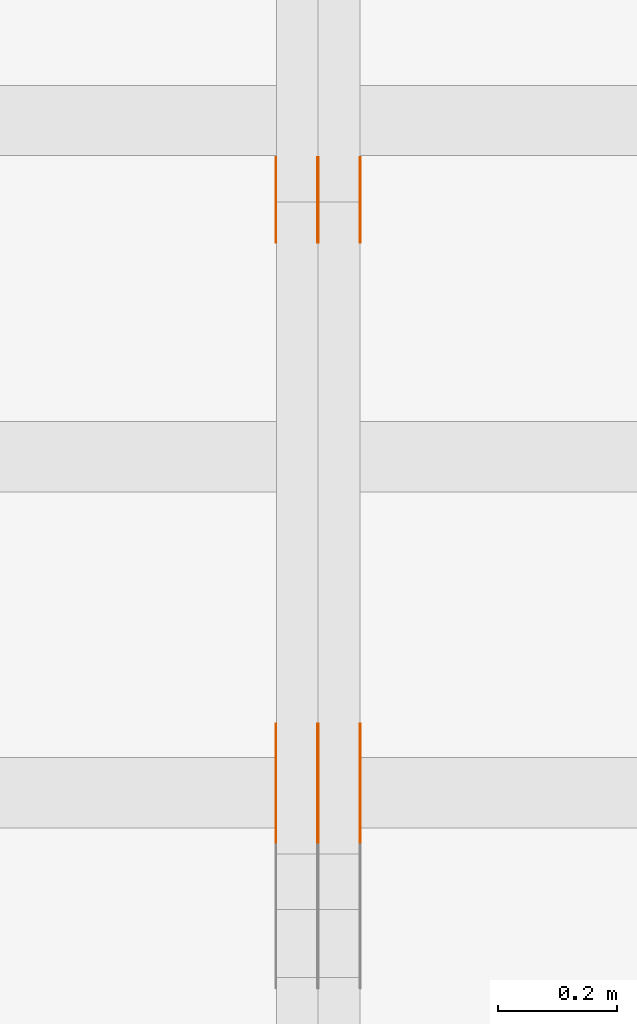
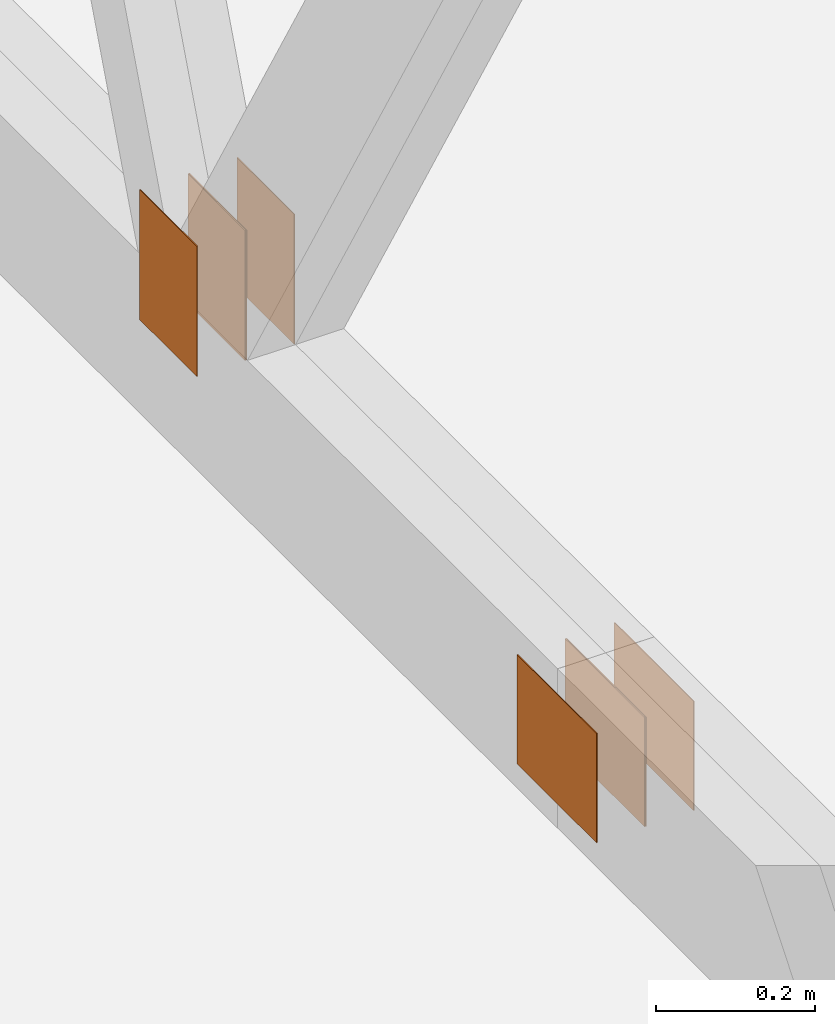
# One storey, part 94 of 189: 8 proxies.
"""IFC2X3 building model written with IfcOpenShell, lengths in millimetres."""

from ifc_helpers import new_model, entity, si_unit, converted_unit, derived_unit, direction, frame, frame_2d, origin, origin_2d_with_axis, place, context, subcontext, project, spatial, rectangle, extrude, source, transform, mapped, material, type_object, type_shapes, element, save


model = new_model("IFC2X3")

# Units and contexts
model_context = context("Model", 3, precision=0.01, world=origin(), true_north=direction((6.12303176911189e-17, 1.0)))
body_context = subcontext(model_context, "Body", "Model", "MODEL_VIEW")
ifc_project = project(units=[si_unit("LENGTHUNIT", "METRE", prefix="MILLI"), si_unit("AREAUNIT", "SQUARE_METRE"), si_unit("VOLUMEUNIT", "CUBIC_METRE"), converted_unit("PLANEANGLEUNIT", "DEGREE", entity("IfcRatioMeasure", 0.0174532925199433), si_unit("PLANEANGLEUNIT", "RADIAN"), dimensions=[0, 0, 0, 0, 0, 0, 0]), si_unit("MASSUNIT", "GRAM", prefix="KILO"), derived_unit("MASSDENSITYUNIT", [(si_unit("MASSUNIT", "GRAM", prefix="KILO"), 1), (si_unit("LENGTHUNIT", "METRE"), -3)]), si_unit("TIMEUNIT", "SECOND"), si_unit("FREQUENCYUNIT", "HERTZ"), si_unit("THERMODYNAMICTEMPERATUREUNIT", "DEGREE_CELSIUS"), derived_unit("THERMALTRANSMITTANCEUNIT", [(si_unit("MASSUNIT", "GRAM", prefix="KILO"), 1), (si_unit("THERMODYNAMICTEMPERATUREUNIT", "KELVIN"), -1), (si_unit("TIMEUNIT", "SECOND"), -3)]), derived_unit("VOLUMETRICFLOWRATEUNIT", [(si_unit("LENGTHUNIT", "METRE"), 3), (si_unit("TIMEUNIT", "SECOND"), -1)]), si_unit("ELECTRICCURRENTUNIT", "AMPERE"), si_unit("ELECTRICVOLTAGEUNIT", "VOLT"), si_unit("POWERUNIT", "WATT"), si_unit("FORCEUNIT", "NEWTON"), si_unit("ILLUMINANCEUNIT", "LUX"), si_unit("LUMINOUSFLUXUNIT", "LUMEN"), si_unit("LUMINOUSINTENSITYUNIT", "CANDELA"), derived_unit("USERDEFINED", [(si_unit("MASSUNIT", "GRAM", prefix="KILO"), -1), (si_unit("LENGTHUNIT", "METRE"), -2), (si_unit("TIMEUNIT", "SECOND"), 3), (si_unit("LUMINOUSFLUXUNIT", "LUMEN"), 1)]), derived_unit("LINEARVELOCITYUNIT", [(si_unit("LENGTHUNIT", "METRE"), 1), (si_unit("TIMEUNIT", "SECOND"), -1)]), si_unit("PRESSUREUNIT", "PASCAL"), derived_unit("USERDEFINED", [(si_unit("LENGTHUNIT", "METRE"), -2), (si_unit("MASSUNIT", "GRAM", prefix="KILO"), 1), (si_unit("TIMEUNIT", "SECOND"), -2)])], contexts=[model_context])

# Site, building, storey
site_placement = place(None, origin())
site = spatial("IfcSite", under=ifc_project, at=site_placement, CompositionType="ELEMENT")
building_placement = place(site_placement, origin())
building = spatial("IfcBuilding", under=site, at=building_placement, CompositionType="ELEMENT")
storey_placement = place(building_placement, origin())
storey = spatial("IfcBuildingStorey", under=building, at=storey_placement, Name="Default", CompositionType="ELEMENT", Elevation=0.0)

# Proxies
ifc_material_1 = material(Name="IfcSurfaceStyle #173742")
building_element_proxy_type_1 = type_object("IfcBuildingElementProxyType", PredefinedType="NOTDEFINED", material=ifc_material_1)
shared_shape_1 = source(origin(), body_context, "Body", "SweptSolid", [
    extrude(rectangle(XDim=200.0, YDim=144.0, at=frame_2d((1.4210854715202e-14, 0.0), x_axis=(1.0, 0.0))), frame((100.0, 72.0, 0.0), z_axis=(0.0, 0.0, 1.0), x_axis=(-1.0, 0.0, 0.0)), (0.0, 0.0, 1.0), 1.3),
])
type_shapes(building_element_proxy_type_1, [shared_shape_1])
proxy_1_placement = place(building_placement, frame((30301.3, 6668.833984375, 145.0), z_axis=(-1.0, 0.0, 0.0), x_axis=(0.0, 0.0, 1.0)))
element("IfcBuildingElementProxy", 1, at=proxy_1_placement, inside=storey, type_object=building_element_proxy_type_1, material=ifc_material_1, context=body_context, shape_type="MappedRepresentation", body=[
    mapped(shared_shape_1, transform((0.0, 0.0, 0.0), scale=1.0)),
])
ifc_material_2 = material(Name="IfcSurfaceStyle #173685")
building_element_proxy_type_2 = type_object("IfcBuildingElementProxyType", PredefinedType="NOTDEFINED", material=ifc_material_2)
shared_shape_2 = source(origin(), body_context, "Body", "SweptSolid", [
    extrude(rectangle(XDim=200.0, YDim=144.0, at=frame_2d((1.4210854715202e-14, 0.0), x_axis=(1.0, 0.0))), frame((100.0, 72.0, 0.0), z_axis=(0.0, 0.0, 1.0), x_axis=(-1.0, 0.0, 0.0)), (0.0, 0.0, 1.0), 1.29999999999998),
])
type_shapes(building_element_proxy_type_2, [shared_shape_2])
proxy_2_placement = place(building_placement, frame((30230.0, 6668.833984375, 145.0), z_axis=(-1.0, 0.0, 0.0), x_axis=(0.0, 0.0, 1.0)))
element("IfcBuildingElementProxy", 2, at=proxy_2_placement, inside=storey, type_object=building_element_proxy_type_2, material=ifc_material_2, context=body_context, shape_type="MappedRepresentation", body=[
    mapped(shared_shape_2, transform((0.0, 0.0, 0.0), scale=1.0)),
])
ifc_material_3 = material(Name="IfcSurfaceStyle #173628")
building_element_proxy_type_3 = type_object("IfcBuildingElementProxyType", PredefinedType="NOTDEFINED", material=ifc_material_3)
shared_shape_3 = source(origin(), body_context, "Body", "SweptSolid", [
    extrude(rectangle(XDim=200.0, YDim=144.0, at=frame_2d((1.4210854715202e-14, 0.0), x_axis=(1.0, 0.0))), frame((100.0, 72.0, 0.0), z_axis=(0.0, 0.0, 1.0), x_axis=(-1.0, 0.0, 0.0)), (0.0, 0.0, 1.0), 1.29999999999998),
])
type_shapes(building_element_proxy_type_3, [shared_shape_3])
proxy_3_placement = place(building_placement, frame((30231.3, 6668.833984375, 145.0), z_axis=(-1.0, 0.0, 0.0), x_axis=(0.0, 0.0, 1.0)))
element("IfcBuildingElementProxy", 3, at=proxy_3_placement, inside=storey, type_object=building_element_proxy_type_3, material=ifc_material_3, context=body_context, shape_type="MappedRepresentation", body=[
    mapped(shared_shape_3, transform((0.0, 0.0, 0.0), scale=1.0)),
])
ifc_material_4 = material(Name="IfcSurfaceStyle #173571")
building_element_proxy_type_4 = type_object("IfcBuildingElementProxyType", PredefinedType="NOTDEFINED", material=ifc_material_4)
shared_shape_4 = source(origin(), body_context, "Body", "SweptSolid", [
    extrude(rectangle(XDim=200.0, YDim=144.0, at=frame_2d((1.4210854715202e-14, 0.0), x_axis=(1.0, 0.0))), frame((100.0, 72.0, 0.0), z_axis=(0.0, 0.0, 1.0), x_axis=(-1.0, 0.0, 0.0)), (0.0, 0.0, 1.0), 1.29999999999999),
])
type_shapes(building_element_proxy_type_4, [shared_shape_4])
proxy_4_placement = place(building_placement, frame((30160.0, 6668.833984375, 145.0), z_axis=(-1.0, 0.0, 0.0), x_axis=(0.0, 0.0, 1.0)))
element("IfcBuildingElementProxy", 4, at=proxy_4_placement, inside=storey, type_object=building_element_proxy_type_4, material=ifc_material_4, context=body_context, shape_type="MappedRepresentation", body=[
    mapped(shared_shape_4, transform((0.0, 0.0, 0.0), scale=1.0)),
])
ifc_material_5 = material(Name="IfcSurfaceStyle #173514")
building_element_proxy_type_5 = type_object("IfcBuildingElementProxyType", PredefinedType="NOTDEFINED", material=ifc_material_5)
shared_shape_5 = source(origin(), body_context, "Body", "SweptSolid", [
    extrude(rectangle(XDim=200.0, YDim=168.0, at=origin_2d_with_axis()), frame((100.0, 84.0, 0.0), z_axis=(0.0, 0.0, 1.0), x_axis=(-1.0, 0.0, 0.0)), (0.0, 0.0, 1.0), 1.3),
])
type_shapes(building_element_proxy_type_5, [shared_shape_5])
proxy_5_placement = place(building_placement, frame((30301.3, 5662.466796875, 206.5), z_axis=(-1.0, 0.0, 0.0), x_axis=(0.0, 1.0, 0.0)))
element("IfcBuildingElementProxy", 5, at=proxy_5_placement, inside=storey, type_object=building_element_proxy_type_5, material=ifc_material_5, context=body_context, shape_type="MappedRepresentation", body=[
    mapped(shared_shape_5, transform((0.0, 0.0, 0.0), scale=1.0)),
])
ifc_material_6 = material(Name="IfcSurfaceStyle #173457")
building_element_proxy_type_6 = type_object("IfcBuildingElementProxyType", PredefinedType="NOTDEFINED", material=ifc_material_6)
shared_shape_6 = source(origin(), body_context, "Body", "SweptSolid", [
    extrude(rectangle(XDim=200.0, YDim=168.0, at=origin_2d_with_axis()), frame((100.0, 84.0, 0.0), z_axis=(0.0, 0.0, 1.0), x_axis=(-1.0, 0.0, 0.0)), (0.0, 0.0, 1.0), 1.29999999999998),
])
type_shapes(building_element_proxy_type_6, [shared_shape_6])
proxy_6_placement = place(building_placement, frame((30230.0, 5662.466796875, 206.5), z_axis=(-1.0, 0.0, 0.0), x_axis=(0.0, 1.0, 0.0)))
element("IfcBuildingElementProxy", 6, at=proxy_6_placement, inside=storey, type_object=building_element_proxy_type_6, material=ifc_material_6, context=body_context, shape_type="MappedRepresentation", body=[
    mapped(shared_shape_6, transform((0.0, 0.0, 0.0), scale=1.0)),
])
ifc_material_7 = material(Name="IfcSurfaceStyle #173400")
building_element_proxy_type_7 = type_object("IfcBuildingElementProxyType", PredefinedType="NOTDEFINED", material=ifc_material_7)
shared_shape_7 = source(origin(), body_context, "Body", "SweptSolid", [
    extrude(rectangle(XDim=200.0, YDim=168.0, at=origin_2d_with_axis()), frame((100.0, 84.0, 0.0), z_axis=(0.0, 0.0, 1.0), x_axis=(-1.0, 0.0, 0.0)), (0.0, 0.0, 1.0), 1.29999999999998),
])
type_shapes(building_element_proxy_type_7, [shared_shape_7])
proxy_7_placement = place(building_placement, frame((30231.3, 5662.466796875, 206.5), z_axis=(-1.0, 0.0, 0.0), x_axis=(0.0, 1.0, 0.0)))
element("IfcBuildingElementProxy", 7, at=proxy_7_placement, inside=storey, type_object=building_element_proxy_type_7, material=ifc_material_7, context=body_context, shape_type="MappedRepresentation", body=[
    mapped(shared_shape_7, transform((0.0, 0.0, 0.0), scale=1.0)),
])
ifc_material_8 = material(Name="IfcSurfaceStyle #173343")
building_element_proxy_type_8 = type_object("IfcBuildingElementProxyType", PredefinedType="NOTDEFINED", material=ifc_material_8)
shared_shape_8 = source(origin(), body_context, "Body", "SweptSolid", [
    extrude(rectangle(XDim=200.0, YDim=168.0, at=origin_2d_with_axis()), frame((100.0, 84.0, 0.0), z_axis=(0.0, 0.0, 1.0), x_axis=(-1.0, 0.0, 0.0)), (0.0, 0.0, 1.0), 1.29999999999999),
])
type_shapes(building_element_proxy_type_8, [shared_shape_8])
proxy_8_placement = place(building_placement, frame((30160.0, 5662.466796875, 206.5), z_axis=(-1.0, 0.0, 0.0), x_axis=(0.0, 1.0, 0.0)))
element("IfcBuildingElementProxy", 8, at=proxy_8_placement, inside=storey, type_object=building_element_proxy_type_8, material=ifc_material_8, context=body_context, shape_type="MappedRepresentation", body=[
    mapped(shared_shape_8, transform((0.0, 0.0, 0.0), scale=1.0)),
])

save(model, "model.ifc")
